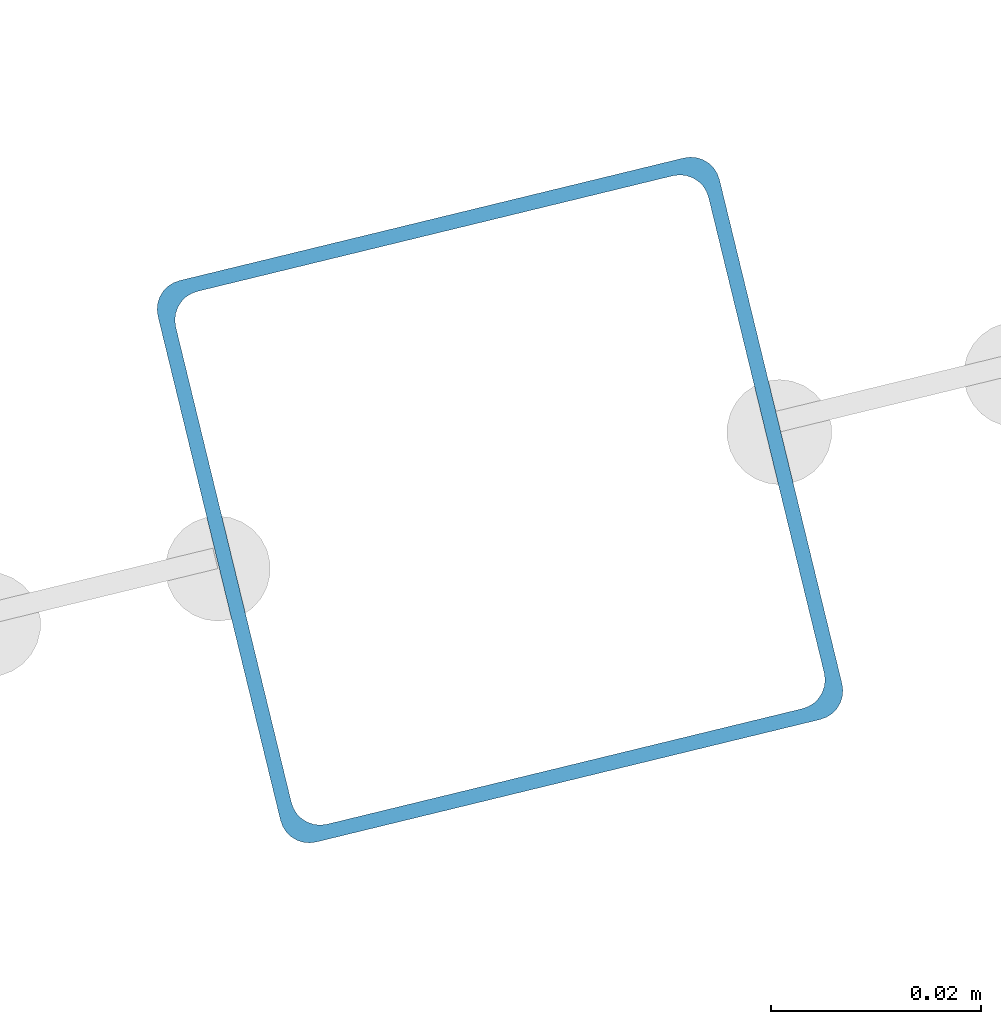
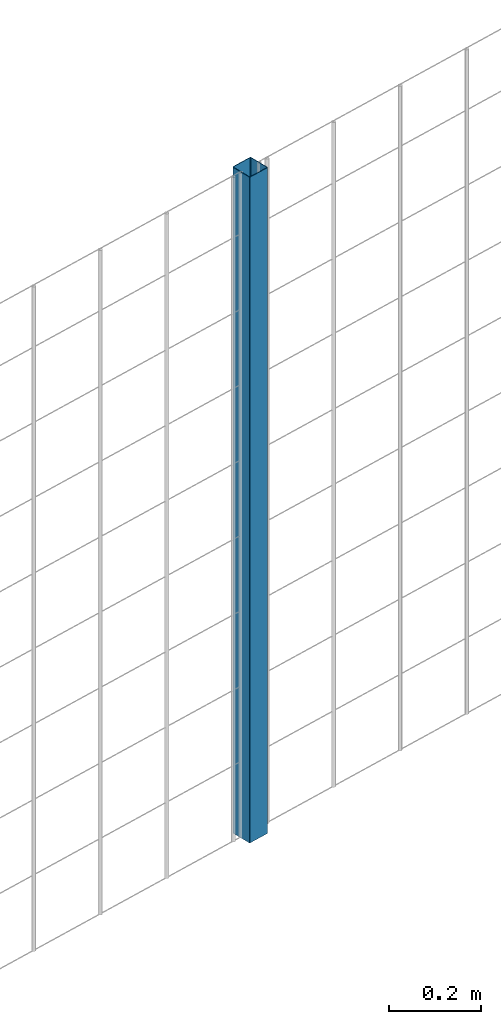
# One storey, part 2 of 10: 1 beam.
"""IFC2X3 building model written with IfcOpenShell, lengths in millimetres."""

from ifc_helpers import new_model, entity, si_unit, converted_unit, derived_unit, direction, frame, frame_2d, origin, place, context, subcontext, project, spatial, polyline, circle_curve, parameter, trimmed, segment, composite_curve, outline, extrude, material, type_object, element, save


model = new_model("IFC2X3")

# Units and contexts
model_context = context("Model", 3, precision=0.01, world=origin(), true_north=direction((6.12303176911189e-17, 1.0)))
body_context = subcontext(model_context, "Body", "Model", "MODEL_VIEW")
ifc_project = project(units=[si_unit("LENGTHUNIT", "METRE", prefix="MILLI"), si_unit("AREAUNIT", "SQUARE_METRE"), si_unit("VOLUMEUNIT", "CUBIC_METRE"), converted_unit("PLANEANGLEUNIT", "DEGREE", entity("IfcRatioMeasure", 0.0174532925199433), si_unit("PLANEANGLEUNIT", "RADIAN"), dimensions=[0, 0, 0, 0, 0, 0, 0]), si_unit("MASSUNIT", "GRAM", prefix="KILO"), derived_unit("MASSDENSITYUNIT", [(si_unit("MASSUNIT", "GRAM", prefix="KILO"), 1), (si_unit("LENGTHUNIT", "METRE"), -3)]), derived_unit("MOMENTOFINERTIAUNIT", [(si_unit("LENGTHUNIT", "METRE"), 4)]), si_unit("TIMEUNIT", "SECOND"), si_unit("FREQUENCYUNIT", "HERTZ"), si_unit("THERMODYNAMICTEMPERATUREUNIT", "DEGREE_CELSIUS"), derived_unit("THERMALTRANSMITTANCEUNIT", [(si_unit("MASSUNIT", "GRAM", prefix="KILO"), 1), (si_unit("THERMODYNAMICTEMPERATUREUNIT", "KELVIN"), -1), (si_unit("TIMEUNIT", "SECOND"), -3)]), derived_unit("VOLUMETRICFLOWRATEUNIT", [(si_unit("LENGTHUNIT", "METRE"), 3), (si_unit("TIMEUNIT", "SECOND"), -1)]), derived_unit("MASSFLOWRATEUNIT", [(si_unit("MASSUNIT", "GRAM", prefix="KILO"), 1), (si_unit("TIMEUNIT", "SECOND"), -1)]), derived_unit("ROTATIONALFREQUENCYUNIT", [(si_unit("TIMEUNIT", "SECOND"), -1)]), si_unit("ELECTRICCURRENTUNIT", "AMPERE"), si_unit("ELECTRICVOLTAGEUNIT", "VOLT"), si_unit("POWERUNIT", "WATT"), si_unit("FORCEUNIT", "NEWTON", prefix="KILO"), si_unit("ILLUMINANCEUNIT", "LUX"), si_unit("LUMINOUSFLUXUNIT", "LUMEN"), si_unit("LUMINOUSINTENSITYUNIT", "CANDELA"), derived_unit("USERDEFINED", [(si_unit("MASSUNIT", "GRAM", prefix="KILO"), -1), (si_unit("LENGTHUNIT", "METRE"), -2), (si_unit("TIMEUNIT", "SECOND"), 3), (si_unit("LUMINOUSFLUXUNIT", "LUMEN"), 1)]), derived_unit("LINEARVELOCITYUNIT", [(si_unit("LENGTHUNIT", "METRE"), 1), (si_unit("TIMEUNIT", "SECOND"), -1)]), si_unit("PRESSUREUNIT", "PASCAL"), derived_unit("USERDEFINED", [(si_unit("LENGTHUNIT", "METRE"), -2), (si_unit("MASSUNIT", "GRAM", prefix="KILO"), 1), (si_unit("TIMEUNIT", "SECOND"), -2)]), derived_unit("LINEARFORCEUNIT", [(si_unit("MASSUNIT", "GRAM", prefix="KILO"), 1), (si_unit("LENGTHUNIT", "METRE"), 1), (si_unit("TIMEUNIT", "SECOND"), -2), (si_unit("LENGTHUNIT", "METRE"), -1)]), derived_unit("PLANARFORCEUNIT", [(si_unit("MASSUNIT", "GRAM", prefix="KILO"), 1), (si_unit("LENGTHUNIT", "METRE"), 1), (si_unit("TIMEUNIT", "SECOND"), -2), (si_unit("LENGTHUNIT", "METRE"), -2)])], contexts=[model_context])

# Site, building, storey
site_placement = place(None, frame((19171.75, -72498.58, 0.0), z_axis=(0.0, 0.0, 1.0), x_axis=(0.971695960795463, 0.236234967296933, 0.0)))
site = spatial("IfcSite", under=ifc_project, at=site_placement, CompositionType="ELEMENT")
building_placement = place(site_placement, origin())
building = spatial("IfcBuilding", under=site, at=building_placement, CompositionType="ELEMENT")
storey_placement = place(building_placement, origin())
storey = spatial("IfcBuildingStorey", under=building, at=storey_placement, Name="01", CompositionType="ELEMENT", Elevation=0.0)

# Beam
ifc_material = material(Name="345")
beam_type = type_object("IfcBeamType", PredefinedType="NOTDEFINED")
beam_placement = place(storey_placement, frame((5171.04, 95.9, 699.02), z_axis=(1.0, 0.0, 0.0), x_axis=(0.0, 0.0, 1.0)))
element("IfcBeam", 1, at=beam_placement, inside=storey, type_object=beam_type, material=ifc_material, context=body_context, shape_type="SweptSolid", body=[
    extrude(outline(composite_curve([segment(trimmed(circle_curve(frame_2d((24.7, -24.7), x_axis=(1.0, 0.0)), 2.79999999999974), [parameter(269.999999999999)], [parameter(1.32311074748882e-12)], True, "PARAMETER"), True, "CONTINUOUS"), segment(polyline([(27.5, -24.7), (27.5, 24.7)]), True, "CONTINUOUS"), segment(trimmed(circle_curve(frame_2d((24.7, 24.7), x_axis=(1.0, 0.0)), 2.79999999999845), [parameter(1.32311074748882e-12)], [parameter(90.0000000000001)], True, "PARAMETER"), True, "CONTINUOUS"), segment(polyline([(24.7, 27.5), (-24.7, 27.5)]), True, "CONTINUOUS"), segment(trimmed(circle_curve(frame_2d((-24.7, 24.7), x_axis=(1.0, 0.0)), 2.79999999999845), [parameter(90.0000000000001)], [parameter(180.0)], True, "PARAMETER"), True, "CONTINUOUS"), segment(polyline([(-27.5, 24.7), (-27.5, -24.7)]), True, "CONTINUOUS"), segment(trimmed(circle_curve(frame_2d((-24.7, -24.7), x_axis=(1.0, 0.0)), 2.79999999999845), [parameter(180.0)], [parameter(269.999999999998)], True, "PARAMETER"), True, "CONTINUOUS"), segment(polyline([(-24.7, -27.5), (24.7, -27.5)]), True, "CONTINUOUS")], self_intersect=False), holes=[composite_curve([segment(polyline([(23.3, -26.1), (-23.3, -26.1)]), True, "CONTINUOUS"), segment(trimmed(circle_curve(frame_2d((-23.3, -23.3), x_axis=(1.0, 0.0)), 2.79999999999973), [parameter(180.0)], [parameter(270.0)], True, "PARAMETER"), False, "CONTINUOUS"), segment(polyline([(-26.1, -23.3), (-26.1, 23.3)]), True, "CONTINUOUS"), segment(trimmed(circle_curve(frame_2d((-23.3, 23.3), x_axis=(1.0, 0.0)), 2.79999999999973), [parameter(90.0000000000004)], [parameter(180.0)], True, "PARAMETER"), False, "CONTINUOUS"), segment(polyline([(-23.3, 26.1), (23.3, 26.1)]), True, "CONTINUOUS"), segment(trimmed(circle_curve(frame_2d((23.3, 23.3), x_axis=(1.0, 0.0)), 2.79999999999973), [parameter(3.56222124323914e-13)], [parameter(90.0000000000004)], True, "PARAMETER"), False, "CONTINUOUS"), segment(polyline([(26.1, 23.3), (26.1, -23.3)]), True, "CONTINUOUS"), segment(trimmed(circle_curve(frame_2d((23.3, -23.3), x_axis=(1.0, 0.0)), 2.80000000000034), [parameter(270.0)], [parameter(4.57999874130747e-13)], True, "PARAMETER"), False, "CONTINUOUS")], self_intersect=False)]), frame((0.0, -29.1, 29.1), z_axis=(1.0, 0.0, 0.0), x_axis=(0.0, -1.0, 0.0)), (0.0, 0.0, 1.0), 1765.97922445826),
])

save(model, "model.ifc")
